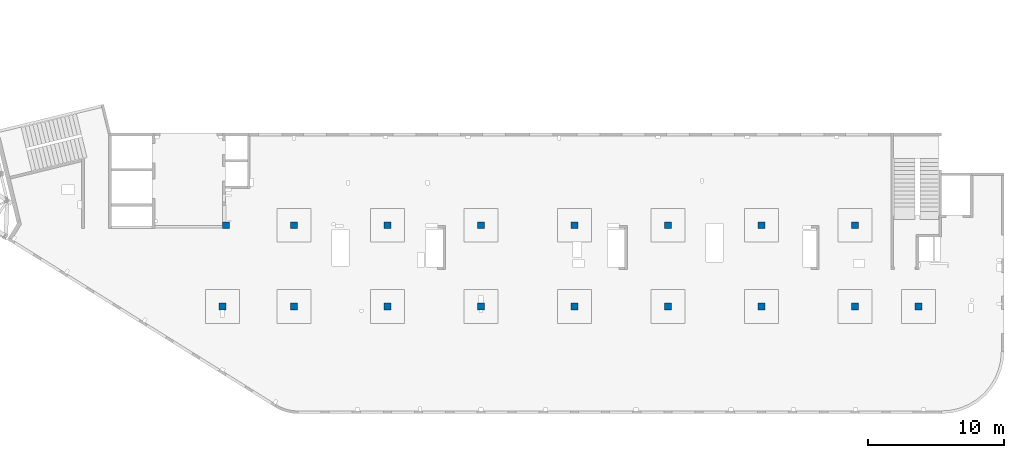
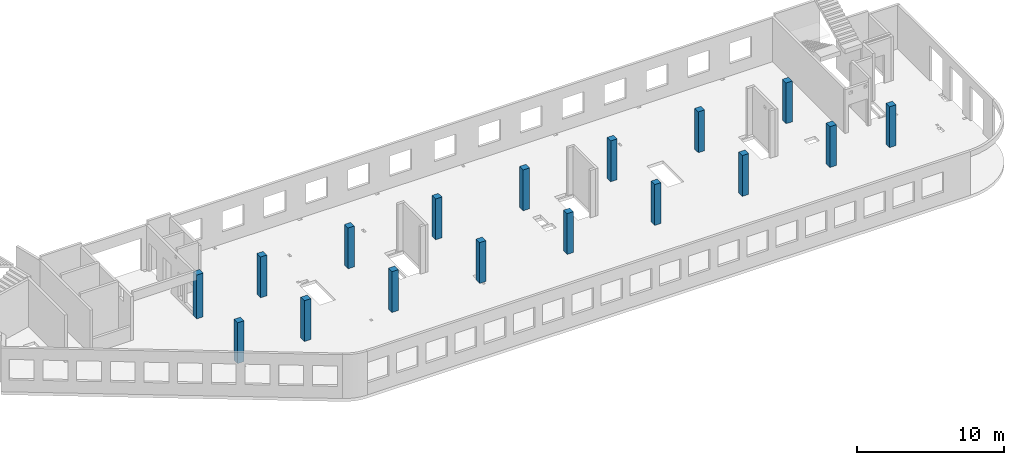
# One storey, part 4 of 93: 17 columns.
"""IFC4 building model written with IfcOpenShell, lengths in millimetres."""

import ifcopenshell
import ifcopenshell.guid

model = None  # the IFC model being written
_history = None  # IfcOwnerHistory: only IFC2X3 demands one
_inside = {}  # id of a spatial element -> (the spatial element, [elements in it])
_under = {}  # id of a project, library or spatial element -> (it, [spatial elements below it])
_declared = {}  # id of a project -> (the project, [libraries it declares])
_typed = {}  # id of a type object -> (the type object, [elements of that type])
_made_of = {}  # id of a material, layer set ... -> (it, [elements and type objects made of it])


def new_model(schema):
    """Start an empty IFC model of exactly this schema.

    Asked for "IFC4X3", IfcOpenShell would pick the latest addendum, in which some entities
    have other attributes; the version numbers below select the first issue.
    IFC2X3 requires an IfcOwnerHistory on every rooted entity: one is made here for all.
    """
    global model, _history
    if schema == "IFC4X3":
        model = ifcopenshell.file(schema_version=(4, 3, 0, 0))
    else:
        model = ifcopenshell.file(schema=schema)
    _inside.clear()
    _under.clear()
    _declared.clear()
    _typed.clear()
    _made_of.clear()
    _history = None
    if model.schema == "IFC2X3":
        org = make("IfcOrganization", Name="unknown")
        user = make(
            "IfcPersonAndOrganization",
            ThePerson=make("IfcPerson", FamilyName="unknown"),
            TheOrganization=org,
        )
        app = make(
            "IfcApplication",
            ApplicationDeveloper=org,
            Version="unknown",
            ApplicationFullName="unknown",
            ApplicationIdentifier="unknown",
        )
        _history = make(
            "IfcOwnerHistory",
            OwningUser=user,
            OwningApplication=app,
            ChangeAction="ADDED",
            CreationDate=0,
        )
    return model


def make(cls, **values):
    """One entity of the class cls with the attributes given. An attribute that is None is left unset."""
    return model.create_entity(
        cls, **{name: value for name, value in values.items() if value is not None}
    )


def entity(cls, *values):
    """Any entity or typed value of the class cls, its attributes in the order of the schema. None: left unset."""
    e = model.create_entity(cls)
    for i, value in enumerate(values):
        if value is not None:
            e[i] = value
    return e


def rooted(cls, **values):
    """An entity with a GlobalId (a new one), such as an element, a storey or a relation."""
    return make(cls, GlobalId=ifcopenshell.guid.new(), OwnerHistory=_history, **values)


def si_unit(unit_type, name, prefix=None):
    """IfcSIUnit, for example si_unit("LENGTHUNIT", "METRE", prefix="MILLI")."""
    return make("IfcSIUnit", UnitType=unit_type, Prefix=prefix, Name=name)


def converted_unit(unit_type, name, factor, base, dimensions=None, offset=None):
    """IfcConversionBasedUnit, such as the inch: factor (a typed value) times the base unit."""
    return make(
        "IfcConversionBasedUnit"
        if offset is None
        else "IfcConversionBasedUnitWithOffset",
        ConversionOffset=offset,
        Dimensions=None
        if dimensions is None
        else entity("IfcDimensionalExponents", *dimensions),
        UnitType=unit_type,
        Name=name,
        ConversionFactor=make(
            "IfcMeasureWithUnit", ValueComponent=factor, UnitComponent=base
        ),
    )


def derived_unit(unit_type, elements):
    """IfcDerivedUnit: a product of units, each with its exponent."""
    return make(
        "IfcDerivedUnit",
        Elements=[
            make("IfcDerivedUnitElement", Unit=unit, Exponent=power)
            for unit, power in elements
        ],
        UnitType=unit_type,
    )


def assignment(units):
    """IfcUnitAssignment: the units of a project."""
    return None if units is None else make("IfcUnitAssignment", Units=units)


def point(xyz):
    """IfcCartesianPoint."""
    return None if xyz is None else make("IfcCartesianPoint", Coordinates=xyz)


def direction(xyz):
    """IfcDirection."""
    return None if xyz is None else make("IfcDirection", DirectionRatios=xyz)


def frame(location, z_axis=None, x_axis=None):
    """IfcAxis2Placement3D, a coordinate frame: its origin and axes. An axis left out is left unset."""
    return make(
        "IfcAxis2Placement3D",
        Location=point(location),
        Axis=direction(z_axis),
        RefDirection=direction(x_axis),
    )


def origin():
    """The frame at (0, 0, 0) with its axes left unset."""
    return frame((0.0, 0.0, 0.0))


def place(relative_to, where):
    """IfcLocalPlacement: puts the frame where relative to a parent placement (None: the world)."""
    return make(
        "IfcLocalPlacement", PlacementRelTo=relative_to, RelativePlacement=where
    )


def context(
    kind, dimensions, precision=None, world=None, true_north=None, identifier=None
):
    """IfcGeometricRepresentationContext, for example the 3D "Model" context."""
    return make(
        "IfcGeometricRepresentationContext",
        ContextIdentifier=identifier,
        ContextType=kind,
        CoordinateSpaceDimension=dimensions,
        Precision=precision,
        WorldCoordinateSystem=world,
        TrueNorth=true_north,
    )


def subcontext(parent, identifier, kind, view, scale=None):
    """IfcGeometricRepresentationSubContext, for example "Body" below "Model"."""
    return make(
        "IfcGeometricRepresentationSubContext",
        ContextIdentifier=identifier,
        ContextType=kind,
        ParentContext=parent,
        TargetScale=scale,
        TargetView=view,
    )


def project(units=None, contexts=None):
    """IfcProject with its units and contexts."""
    return rooted(
        "IfcProject",
        Name="project",
        RepresentationContexts=contexts,
        UnitsInContext=assignment(units),
    )


def spatial(cls, under=None, at=None, **own):
    """A site, building, storey or space (cls), placed at a placement, below another one or the project."""
    s = rooted(cls, ObjectPlacement=at, **own)
    if under is not None:
        _under.setdefault(under.id(), (under, []))[1].append(s)
    return s


def point_list(points):
    """IfcCartesianPointList2D or 3D."""
    cls = (
        "IfcCartesianPointList2D" if len(points[0]) == 2 else "IfcCartesianPointList3D"
    )
    return make(cls, CoordList=points)


def indexed_curve(points, segments=None, self_intersect=None):
    """IfcIndexedPolyCurve: lines and arcs through numbered points (the first is 1)."""
    return make(
        "IfcIndexedPolyCurve",
        Points=point_list(points),
        Segments=segments,
        SelfIntersect=self_intersect,
    )


def outline(outer, holes=None, kind="AREA"):
    """IfcArbitraryClosedProfileDef: a profile drawn as a closed curve; with holes, ...WithVoids."""
    if holes is None:
        return make("IfcArbitraryClosedProfileDef", ProfileType=kind, OuterCurve=outer)
    return make(
        "IfcArbitraryProfileDefWithVoids",
        ProfileType=kind,
        OuterCurve=outer,
        InnerCurves=holes,
    )


def extrude(swept, where, along, depth):
    """IfcExtrudedAreaSolid: the profile swept, set in the frame where, extruded along a direction by depth."""
    return make(
        "IfcExtrudedAreaSolid",
        SweptArea=swept,
        Position=where,
        ExtrudedDirection=direction(along),
        Depth=depth,
    )


def shape(context_of_items, identifier, shape_type, items):
    """IfcShapeRepresentation: the items that make up one representation, for example the "Body"."""
    return make(
        "IfcShapeRepresentation",
        ContextOfItems=context_of_items,
        RepresentationIdentifier=identifier,
        RepresentationType=shape_type,
        Items=items,
    )


def source(mapping_origin, context_of_items, identifier, shape_type, items):
    """IfcRepresentationMap: a shape defined once, which mapped items show again and again."""
    return make(
        "IfcRepresentationMap",
        MappingOrigin=mapping_origin,
        MappedRepresentation=shape(context_of_items, identifier, shape_type, items),
    )


def transform(
    local_origin,
    x_axis=None,
    y_axis=None,
    z_axis=None,
    scale=None,
    scale2=None,
    scale3=None,
    uniform=True,
):
    """IfcCartesianTransformationOperator3D, or its non-uniform kind. x_axis, y_axis, z_axis: its Axis1, 2, 3."""
    if uniform:
        return make(
            "IfcCartesianTransformationOperator3D",
            Axis1=direction(x_axis),
            Axis2=direction(y_axis),
            LocalOrigin=point(local_origin),
            Scale=scale,
            Axis3=direction(z_axis),
        )
    return make(
        "IfcCartesianTransformationOperator3DnonUniform",
        Axis1=direction(x_axis),
        Axis2=direction(y_axis),
        LocalOrigin=point(local_origin),
        Scale=scale,
        Axis3=direction(z_axis),
        Scale2=scale2,
        Scale3=scale3,
    )


def mapped(mapping_source, mapping_target):
    """IfcMappedItem: shows the shape of a source again, moved by a transform."""
    return make(
        "IfcMappedItem", MappingSource=mapping_source, MappingTarget=mapping_target
    )


def material(Name=None, Category=None):
    """IfcMaterial."""
    return make("IfcMaterial", Name=Name, Category=Category)


def made_of(thing, what):
    """Note that an element or type object is made of a material, layer set ...; save() writes the relation."""
    if what is not None:
        _made_of.setdefault(what.id(), (what, []))[1].append(thing)
    return thing


def type_object(cls, material=None, **own):
    """A type object (cls), such as IfcWallType, which elements share."""
    return made_of(rooted(cls, **own), material)


def type_shapes(of_type, sources):
    """Give a type object the sources (RepresentationMaps) that its elements show as mapped items."""
    of_type.RepresentationMaps = sources


def element(
    cls,
    number,
    at=None,
    inside=None,
    cuts=None,
    type_object=None,
    material=None,
    context=None,
    identifier="Body",
    shape_type=None,
    held_by="IfcProductDefinitionShape",
    body=None,
    shapes=None,
    **own,
):
    """One element of the class cls, such as IfcWall. Its Tag is "e" and its number.

    at: its placement. inside: the storey or other place that contains it. cuts: it is an
    opening in that element (IfcRelVoidsElement). A single representation is given by context,
    identifier, shape_type and body (its items); several are given by shapes. held_by: the class
    of the entity that holds the representations. save() writes the other relations.
    """
    e = rooted(cls, Tag="e%d" % number, ObjectPlacement=at, **own)
    if body is not None:
        shapes = [shape(context, identifier, shape_type, body)]
    if shapes is not None:
        e.Representation = make(held_by, Representations=shapes)
    if inside is not None:
        _inside.setdefault(inside.id(), (inside, []))[1].append(e)
    if cuts is not None:
        rooted(
            "IfcRelVoidsElement", RelatingBuildingElement=cuts, RelatedOpeningElement=e
        )
    if type_object is not None:
        _typed.setdefault(type_object.id(), (type_object, []))[1].append(e)
    return made_of(e, material)


def aggregate(whole, parts):
    """IfcRelAggregates: a whole, such as a stair, and the parts it consists of."""
    return rooted("IfcRelAggregates", RelatingObject=whole, RelatedObjects=parts)


def save(model, path):
    """Write the relations noted so far, then the file.

    IfcRelAggregates (storeys below a building ...), IfcRelContainedInSpatialStructure (elements
    in a storey), IfcRelDefinesByType, IfcRelAssociatesMaterial and IfcRelDeclares: one each for
    every whole, place, type object, material and project.
    """
    for whole, parts in _under.values():
        aggregate(whole, parts)
    for where, things in _inside.values():
        rooted(
            "IfcRelContainedInSpatialStructure",
            RelatedElements=things,
            RelatingStructure=where,
        )
    for kind, things in _typed.values():
        rooted("IfcRelDefinesByType", RelatedObjects=things, RelatingType=kind)
    for what, things in _made_of.values():
        rooted("IfcRelAssociatesMaterial", RelatedObjects=things, RelatingMaterial=what)
    for by, libraries in _declared.values():
        rooted("IfcRelDeclares", RelatingContext=by, RelatedDefinitions=libraries)
    model.write(path)


model = new_model("IFC4")

# Units and contexts
model_context = context("Model", 3, precision=0.01, world=origin(), true_north=direction((6.12303176911189e-17, 1.0)))
plan_context = context("Plan", 3, precision=0.01, world=origin(), true_north=direction((6.12303176911189e-17, 1.0)))
body_context = subcontext(model_context, "Body", "Model", "MODEL_VIEW")
ifc_project = project(units=[si_unit("LENGTHUNIT", "METRE", prefix="MILLI"), si_unit("AREAUNIT", "SQUARE_METRE"), si_unit("VOLUMEUNIT", "CUBIC_METRE"), converted_unit("PLANEANGLEUNIT", "DEGREE", entity("IfcRatioMeasure", 0.0174532925199433), si_unit("PLANEANGLEUNIT", "RADIAN"), dimensions=[0, 0, 0, 0, 0, 0, 0]), si_unit("MASSUNIT", "GRAM", prefix="KILO"), derived_unit("MASSDENSITYUNIT", [(si_unit("MASSUNIT", "GRAM", prefix="KILO"), 1), (si_unit("LENGTHUNIT", "METRE"), -3)]), derived_unit("MOMENTOFINERTIAUNIT", [(si_unit("LENGTHUNIT", "METRE"), 4)]), si_unit("TIMEUNIT", "SECOND"), si_unit("FREQUENCYUNIT", "HERTZ"), si_unit("THERMODYNAMICTEMPERATUREUNIT", "DEGREE_CELSIUS"), derived_unit("THERMALTRANSMITTANCEUNIT", [(si_unit("MASSUNIT", "GRAM", prefix="KILO"), 1), (si_unit("THERMODYNAMICTEMPERATUREUNIT", "KELVIN"), -1), (si_unit("TIMEUNIT", "SECOND"), -3)]), derived_unit("VOLUMETRICFLOWRATEUNIT", [(si_unit("LENGTHUNIT", "METRE"), 3), (si_unit("TIMEUNIT", "SECOND"), -1)]), derived_unit("MASSFLOWRATEUNIT", [(si_unit("MASSUNIT", "GRAM", prefix="KILO"), 1), (si_unit("TIMEUNIT", "SECOND"), -1)]), derived_unit("ROTATIONALFREQUENCYUNIT", [(si_unit("TIMEUNIT", "SECOND"), -1)]), si_unit("ELECTRICCURRENTUNIT", "AMPERE"), si_unit("ELECTRICVOLTAGEUNIT", "VOLT"), si_unit("POWERUNIT", "WATT"), si_unit("FORCEUNIT", "NEWTON", prefix="KILO"), si_unit("ILLUMINANCEUNIT", "LUX"), si_unit("LUMINOUSFLUXUNIT", "LUMEN"), si_unit("LUMINOUSINTENSITYUNIT", "CANDELA"), derived_unit("USERDEFINED", [(si_unit("MASSUNIT", "GRAM", prefix="KILO"), -1), (si_unit("LENGTHUNIT", "METRE"), -2), (si_unit("TIMEUNIT", "SECOND"), 3), (si_unit("LUMINOUSFLUXUNIT", "LUMEN"), 1)]), derived_unit("LINEARVELOCITYUNIT", [(si_unit("LENGTHUNIT", "METRE"), 1), (si_unit("TIMEUNIT", "SECOND"), -1)]), si_unit("PRESSUREUNIT", "PASCAL"), derived_unit("USERDEFINED", [(si_unit("LENGTHUNIT", "METRE"), -2), (si_unit("MASSUNIT", "GRAM", prefix="KILO"), 1), (si_unit("TIMEUNIT", "SECOND"), -2)]), derived_unit("LINEARFORCEUNIT", [(si_unit("MASSUNIT", "GRAM", prefix="KILO"), 1), (si_unit("LENGTHUNIT", "METRE"), 1), (si_unit("TIMEUNIT", "SECOND"), -2), (si_unit("LENGTHUNIT", "METRE"), -1)]), derived_unit("PLANARFORCEUNIT", [(si_unit("MASSUNIT", "GRAM", prefix="KILO"), 1), (si_unit("LENGTHUNIT", "METRE"), 1), (si_unit("TIMEUNIT", "SECOND"), -2), (si_unit("LENGTHUNIT", "METRE"), -2)])], contexts=[model_context, plan_context])

# Site, building, storey
site_placement = place(None, origin())
site = spatial("IfcSite", under=ifc_project, at=site_placement, CompositionType="ELEMENT")
building_placement = place(site_placement, origin())
building = spatial("IfcBuilding", under=site, at=building_placement, CompositionType="ELEMENT")
storey_placement = place(building_placement, frame((0.0, 0.0, 15900.0)))
storey = spatial("IfcBuildingStorey", under=building, at=storey_placement, CompositionType="ELEMENT", Elevation=15900.0)

# Columns
ifc_material = material()
column_type_1 = type_object("IfcColumnType", PredefinedType="COLUMN", material=ifc_material)
shared_shape_1 = source(origin(), body_context, "Body", "SweptSolid", [
    extrude(outline(indexed_curve([(-249.999999999999, -249.999999999999), (250.000000000001, -249.999999999999), (249.999999999999, 249.999999999999), (-250.000000000001, 249.999999999999), (-249.999999999999, -249.999999999999)], self_intersect=False)), frame((15899.9995239258, 7699.99922635584, 15750.0), z_axis=(0.0, 0.0, 1.0), x_axis=(0.0, -1.0, 0.0)), (0.0, 0.0, 1.0), 3400.0),
])
type_shapes(column_type_1, [shared_shape_1])
column_1_placement = place(storey_placement, frame((0.0, 0.0, -15900.0)))
element("IfcColumn", 1, at=column_1_placement, inside=storey, type_object=column_type_1, PredefinedType="COLUMN", context=body_context, shape_type="MappedRepresentation", body=[
    mapped(shared_shape_1, transform((0.0, 0.0, 0.0), scale=1.0)),
])
column_type_2 = type_object("IfcColumnType", PredefinedType="COLUMN", material=ifc_material)
shared_shape_2 = source(origin(), body_context, "Body", "SweptSolid", [
    extrude(outline(indexed_curve([(-249.999999999999, -249.999999999999), (250.000000000001, -249.999999999999), (249.999999999999, 249.999999999999), (-250.000000000001, 249.999999999999), (-249.999999999999, -249.999999999999)], self_intersect=False)), frame((21170.0002685547, 7699.99922635582, 15750.0), z_axis=(0.0, 0.0, 1.0), x_axis=(0.0, -1.0, 0.0)), (0.0, 0.0, 1.0), 3400.0),
])
type_shapes(column_type_2, [shared_shape_2])
column_2_placement = place(storey_placement, frame((0.0, 0.0, -15900.0)))
element("IfcColumn", 2, at=column_2_placement, inside=storey, type_object=column_type_2, PredefinedType="COLUMN", context=body_context, shape_type="MappedRepresentation", body=[
    mapped(shared_shape_2, transform((0.0, 0.0, 0.0), scale=1.0)),
])
column_type_3 = type_object("IfcColumnType", PredefinedType="COLUMN", material=ifc_material)
shared_shape_3 = source(origin(), body_context, "Body", "SweptSolid", [
    extrude(outline(indexed_curve([(-249.999999999999, -249.999999999999), (250.000000000001, -249.999999999999), (250.000000000001, 249.999999999999), (-249.999999999999, 249.999999999999), (-249.999999999999, -249.999999999999)], self_intersect=False)), frame((28070.0002685547, 7699.9992263558, 15750.0), z_axis=(0.0, 0.0, 1.0), x_axis=(0.0, -1.0, 0.0)), (0.0, 0.0, 1.0), 3400.0),
])
type_shapes(column_type_3, [shared_shape_3])
column_3_placement = place(storey_placement, frame((0.0, 0.0, -15900.0)))
element("IfcColumn", 3, at=column_3_placement, inside=storey, type_object=column_type_3, PredefinedType="COLUMN", context=body_context, shape_type="MappedRepresentation", body=[
    mapped(shared_shape_3, transform((0.0, 0.0, 0.0), scale=1.0)),
])
column_type_4 = type_object("IfcColumnType", PredefinedType="COLUMN", material=ifc_material)
shared_shape_4 = source(origin(), body_context, "Body", "SweptSolid", [
    extrude(outline(indexed_curve([(-249.999999999999, -249.999999999999), (250.000000000001, -249.999999999999), (249.999999999999, 249.999999999999), (-250.000000000001, 249.999999999999), (-249.999999999999, -249.999999999999)], self_intersect=False)), frame((34970.0002685547, 7699.99922635577, 15750.0), z_axis=(0.0, 0.0, 1.0), x_axis=(0.0, -1.0, 0.0)), (0.0, 0.0, 1.0), 3400.0),
])
type_shapes(column_type_4, [shared_shape_4])
column_4_placement = place(storey_placement, frame((0.0, 0.0, -15900.0)))
element("IfcColumn", 4, at=column_4_placement, inside=storey, type_object=column_type_4, PredefinedType="COLUMN", context=body_context, shape_type="MappedRepresentation", body=[
    mapped(shared_shape_4, transform((0.0, 0.0, 0.0), scale=1.0)),
])
column_type_5 = type_object("IfcColumnType", PredefinedType="COLUMN", material=ifc_material)
shared_shape_5 = source(origin(), body_context, "Body", "SweptSolid", [
    extrude(outline(indexed_curve([(-249.999999999999, -250.000000000004), (250.000000000001, -250.000000000004), (250.000000000001, 249.999999999995), (-249.999999999999, 250.000000000004), (-249.999999999999, -250.000000000004)], self_intersect=False)), frame((41870.0002685547, 7699.99922635575, 15750.0), z_axis=(0.0, 0.0, 1.0), x_axis=(0.0, -1.0, 0.0)), (0.0, 0.0, 1.0), 3400.0),
])
type_shapes(column_type_5, [shared_shape_5])
column_5_placement = place(storey_placement, frame((0.0, 0.0, -15900.0)))
element("IfcColumn", 5, at=column_5_placement, inside=storey, type_object=column_type_5, PredefinedType="COLUMN", context=body_context, shape_type="MappedRepresentation", body=[
    mapped(shared_shape_5, transform((0.0, 0.0, 0.0), scale=1.0)),
])
column_type_6 = type_object("IfcColumnType", PredefinedType="COLUMN", material=ifc_material)
shared_shape_6 = source(origin(), body_context, "Body", "SweptSolid", [
    extrude(outline(indexed_curve([(-249.999999999999, -250.000000000004), (250.000000000001, -250.000000000004), (249.999999999999, 249.999999999995), (-250.000000000001, 250.000000000004), (-249.999999999999, -250.000000000004)], self_intersect=False)), frame((48770.0002685547, 7699.99922635573, 15750.0), z_axis=(0.0, 0.0, 1.0), x_axis=(0.0, -1.0, 0.0)), (0.0, 0.0, 1.0), 3400.0),
])
type_shapes(column_type_6, [shared_shape_6])
column_6_placement = place(storey_placement, frame((0.0, 0.0, -15900.0)))
element("IfcColumn", 6, at=column_6_placement, inside=storey, type_object=column_type_6, PredefinedType="COLUMN", context=body_context, shape_type="MappedRepresentation", body=[
    mapped(shared_shape_6, transform((0.0, 0.0, 0.0), scale=1.0)),
])
column_type_7 = type_object("IfcColumnType", PredefinedType="COLUMN", material=ifc_material)
shared_shape_7 = source(origin(), body_context, "Body", "SweptSolid", [
    extrude(outline(indexed_curve([(-249.999999999999, -250.000000000004), (250.000000000001, -250.000000000004), (250.000000000001, 249.999999999995), (-249.999999999999, 250.000000000004), (-249.999999999999, -250.000000000004)], self_intersect=False)), frame((55670.0002685547, 7699.99922635571, 15750.0), z_axis=(0.0, 0.0, 1.0), x_axis=(0.0, -1.0, 0.0)), (0.0, 0.0, 1.0), 3400.0),
])
type_shapes(column_type_7, [shared_shape_7])
column_7_placement = place(storey_placement, frame((0.0, 0.0, -15900.0)))
element("IfcColumn", 7, at=column_7_placement, inside=storey, type_object=column_type_7, PredefinedType="COLUMN", context=body_context, shape_type="MappedRepresentation", body=[
    mapped(shared_shape_7, transform((0.0, 0.0, 0.0), scale=1.0)),
])
column_type_8 = type_object("IfcColumnType", PredefinedType="COLUMN", material=ifc_material)
shared_shape_8 = source(origin(), body_context, "Body", "SweptSolid", [
    extrude(outline(indexed_curve([(-249.999999999999, -250.000000000004), (250.000000000001, -250.000000000004), (249.999999999999, 249.999999999995), (-250.000000000001, 250.000000000004), (-249.999999999999, -250.000000000004)], self_intersect=False)), frame((62570.0002685547, 7699.99922635568, 15750.0), z_axis=(0.0, 0.0, 1.0), x_axis=(0.0, -1.0, 0.0)), (0.0, 0.0, 1.0), 3400.0),
])
type_shapes(column_type_8, [shared_shape_8])
column_8_placement = place(storey_placement, frame((0.0, 0.0, -15900.0)))
element("IfcColumn", 8, at=column_8_placement, inside=storey, type_object=column_type_8, PredefinedType="COLUMN", context=body_context, shape_type="MappedRepresentation", body=[
    mapped(shared_shape_8, transform((0.0, 0.0, 0.0), scale=1.0)),
])
column_type_9 = type_object("IfcColumnType", PredefinedType="COLUMN", material=ifc_material)
shared_shape_9 = source(origin(), body_context, "Body", "SweptSolid", [
    extrude(outline(indexed_curve([(-249.999999999999, -250.000000000004), (250.000000000001, -250.000000000004), (249.999999999999, 249.999999999995), (-250.000000000001, 250.000000000004), (-249.999999999999, -250.000000000004)], self_intersect=False)), frame((67270.0002685547, 7699.99922635567, 15750.0), z_axis=(0.0, 0.0, 1.0), x_axis=(0.0, -1.0, 0.0)), (0.0, 0.0, 1.0), 3400.0),
])
type_shapes(column_type_9, [shared_shape_9])
column_9_placement = place(storey_placement, frame((0.0, 0.0, -15900.0)))
element("IfcColumn", 9, at=column_9_placement, inside=storey, type_object=column_type_9, PredefinedType="COLUMN", context=body_context, shape_type="MappedRepresentation", body=[
    mapped(shared_shape_9, transform((0.0, 0.0, 0.0), scale=1.0)),
])
column_type_10 = type_object("IfcColumnType", PredefinedType="COLUMN", material=ifc_material)
shared_shape_10 = source(origin(), body_context, "Body", "SweptSolid", [
    extrude(outline(indexed_curve([(-249.999999999999, -250.000000000004), (249.999999999999, -250.000000000004), (249.999999999999, 249.999999999995), (-249.999999999999, 250.000000000004), (-249.999999999999, -250.000000000004)], self_intersect=False)), frame((62570.0002685547, 13699.9992263555, 15750.0), z_axis=(0.0, 0.0, 1.0), x_axis=(0.0, -1.0, 0.0)), (0.0, 0.0, 1.0), 3400.0),
])
type_shapes(column_type_10, [shared_shape_10])
column_10_placement = place(storey_placement, frame((0.0, 0.0, -15900.0)))
element("IfcColumn", 10, at=column_10_placement, inside=storey, type_object=column_type_10, PredefinedType="COLUMN", context=body_context, shape_type="MappedRepresentation", body=[
    mapped(shared_shape_10, transform((0.0, 0.0, 0.0), scale=1.0)),
])
column_type_11 = type_object("IfcColumnType", PredefinedType="COLUMN", material=ifc_material)
shared_shape_11 = source(origin(), body_context, "Body", "SweptSolid", [
    extrude(outline(indexed_curve([(-249.999999999999, -250.000000000004), (249.999999999999, -250.000000000004), (249.999999999999, 249.999999999995), (-249.999999999999, 250.000000000004), (-249.999999999999, -250.000000000004)], self_intersect=False)), frame((55670.0002685547, 13699.9992263555, 15750.0), z_axis=(0.0, 0.0, 1.0), x_axis=(0.0, -1.0, 0.0)), (0.0, 0.0, 1.0), 3400.0),
])
type_shapes(column_type_11, [shared_shape_11])
column_11_placement = place(storey_placement, frame((0.0, 0.0, -15900.0)))
element("IfcColumn", 11, at=column_11_placement, inside=storey, type_object=column_type_11, PredefinedType="COLUMN", context=body_context, shape_type="MappedRepresentation", body=[
    mapped(shared_shape_11, transform((0.0, 0.0, 0.0), scale=1.0)),
])
column_type_12 = type_object("IfcColumnType", PredefinedType="COLUMN", material=ifc_material)
shared_shape_12 = source(origin(), body_context, "Body", "SweptSolid", [
    extrude(outline(indexed_curve([(-249.999999999999, -250.000000000004), (249.999999999999, -250.000000000004), (249.999999999999, 249.999999999995), (-249.999999999999, 250.000000000004), (-249.999999999999, -250.000000000004)], self_intersect=False)), frame((48770.0002685547, 13699.9992263556, 15750.0), z_axis=(0.0, 0.0, 1.0), x_axis=(0.0, -1.0, 0.0)), (0.0, 0.0, 1.0), 3400.0),
])
type_shapes(column_type_12, [shared_shape_12])
column_12_placement = place(storey_placement, frame((0.0, 0.0, -15900.0)))
element("IfcColumn", 12, at=column_12_placement, inside=storey, type_object=column_type_12, PredefinedType="COLUMN", context=body_context, shape_type="MappedRepresentation", body=[
    mapped(shared_shape_12, transform((0.0, 0.0, 0.0), scale=1.0)),
])
column_type_13 = type_object("IfcColumnType", PredefinedType="COLUMN", material=ifc_material)
shared_shape_13 = source(origin(), body_context, "Body", "SweptSolid", [
    extrude(outline(indexed_curve([(-249.999999999999, -250.000000000004), (249.999999999999, -250.000000000004), (249.999999999999, 249.999999999995), (-249.999999999999, 250.000000000004), (-249.999999999999, -250.000000000004)], self_intersect=False)), frame((41870.0002685547, 13699.9992263556, 15750.0), z_axis=(0.0, 0.0, 1.0), x_axis=(0.0, -1.0, 0.0)), (0.0, 0.0, 1.0), 3400.0),
])
type_shapes(column_type_13, [shared_shape_13])
column_13_placement = place(storey_placement, frame((0.0, 0.0, -15900.0)))
element("IfcColumn", 13, at=column_13_placement, inside=storey, type_object=column_type_13, PredefinedType="COLUMN", context=body_context, shape_type="MappedRepresentation", body=[
    mapped(shared_shape_13, transform((0.0, 0.0, 0.0), scale=1.0)),
])
column_type_14 = type_object("IfcColumnType", PredefinedType="COLUMN", material=ifc_material)
shared_shape_14 = source(origin(), body_context, "Body", "SweptSolid", [
    extrude(outline(indexed_curve([(-249.999999999999, -249.999999999999), (249.999999999999, -249.999999999999), (249.999999999999, 249.999999999999), (-249.999999999999, 249.999999999999), (-249.999999999999, -249.999999999999)], self_intersect=False)), frame((34970.0002685547, 13699.9992263556, 15750.0), z_axis=(0.0, 0.0, 1.0), x_axis=(0.0, -1.0, 0.0)), (0.0, 0.0, 1.0), 3400.0),
])
type_shapes(column_type_14, [shared_shape_14])
column_14_placement = place(storey_placement, frame((0.0, 0.0, -15900.0)))
element("IfcColumn", 14, at=column_14_placement, inside=storey, type_object=column_type_14, PredefinedType="COLUMN", context=body_context, shape_type="MappedRepresentation", body=[
    mapped(shared_shape_14, transform((0.0, 0.0, 0.0), scale=1.0)),
])
column_type_15 = type_object("IfcColumnType", PredefinedType="COLUMN", material=ifc_material)
shared_shape_15 = source(origin(), body_context, "Body", "SweptSolid", [
    extrude(outline(indexed_curve([(-249.999999999999, -249.999999999999), (249.999999999999, -249.999999999999), (249.999999999999, 249.999999999999), (-249.999999999999, 249.999999999999), (-249.999999999999, -249.999999999999)], self_intersect=False)), frame((28070.0002685547, 13699.9992263556, 15750.0), z_axis=(0.0, 0.0, 1.0), x_axis=(0.0, -1.0, 0.0)), (0.0, 0.0, 1.0), 3400.0),
])
type_shapes(column_type_15, [shared_shape_15])
column_15_placement = place(storey_placement, frame((0.0, 0.0, -15900.0)))
element("IfcColumn", 15, at=column_15_placement, inside=storey, type_object=column_type_15, PredefinedType="COLUMN", context=body_context, shape_type="MappedRepresentation", body=[
    mapped(shared_shape_15, transform((0.0, 0.0, 0.0), scale=1.0)),
])
column_type_16 = type_object("IfcColumnType", PredefinedType="COLUMN", material=ifc_material)
shared_shape_16 = source(origin(), body_context, "Body", "SweptSolid", [
    extrude(outline(indexed_curve([(-249.999999999999, -249.999999999999), (249.999999999999, -249.999999999999), (249.999999999999, 249.999999999999), (-249.999999999999, 249.999999999999), (-249.999999999999, -249.999999999999)], self_intersect=False)), frame((21170.0002685547, 13699.9992263556, 15750.0), z_axis=(0.0, 0.0, 1.0), x_axis=(0.0, -1.0, 0.0)), (0.0, 0.0, 1.0), 3400.0),
])
type_shapes(column_type_16, [shared_shape_16])
column_16_placement = place(storey_placement, frame((0.0, 0.0, -15900.0)))
element("IfcColumn", 16, at=column_16_placement, inside=storey, type_object=column_type_16, PredefinedType="COLUMN", context=body_context, shape_type="MappedRepresentation", body=[
    mapped(shared_shape_16, transform((0.0, 0.0, 0.0), scale=1.0)),
])
column_type_17 = type_object("IfcColumnType", PredefinedType="COLUMN", material=ifc_material)
shared_shape_17 = source(origin(), body_context, "Body", "SweptSolid", [
    extrude(outline(indexed_curve([(-249.999999999999, -249.999999999999), (249.999999999999, -249.999999999999), (249.999999999999, 249.999999999999), (-249.999999999999, 249.999999999999), (-249.999999999999, -249.999999999999)], self_intersect=False)), frame((16149.9987792969, 13699.9986907723, 15750.0), z_axis=(0.0, 0.0, 1.0), x_axis=(0.0, -1.0, 0.0)), (0.0, 0.0, 1.0), 3650.0),
])
type_shapes(column_type_17, [shared_shape_17])
column_17_placement = place(storey_placement, frame((0.0, 0.0, -15900.0)))
element("IfcColumn", 17, at=column_17_placement, inside=storey, type_object=column_type_17, PredefinedType="COLUMN", context=body_context, shape_type="MappedRepresentation", body=[
    mapped(shared_shape_17, transform((0.0, 0.0, 0.0), scale=1.0)),
])

save(model, "model.ifc")
